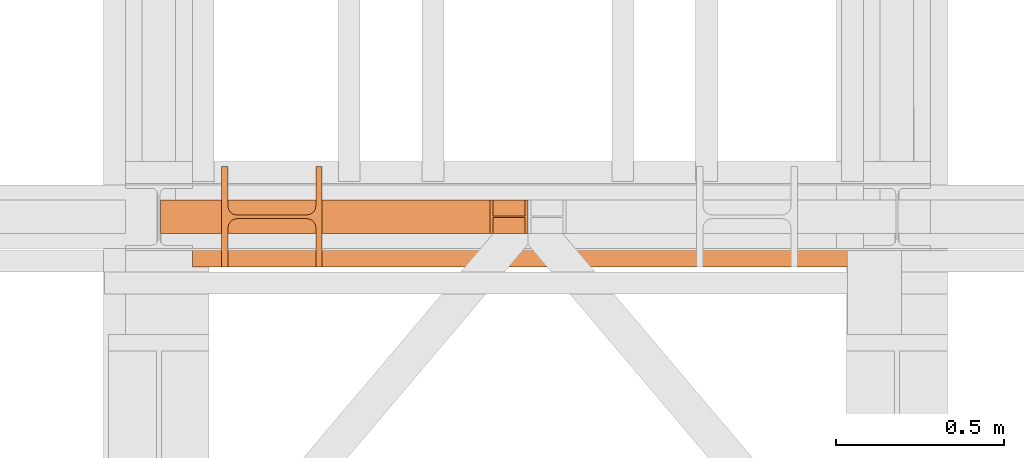
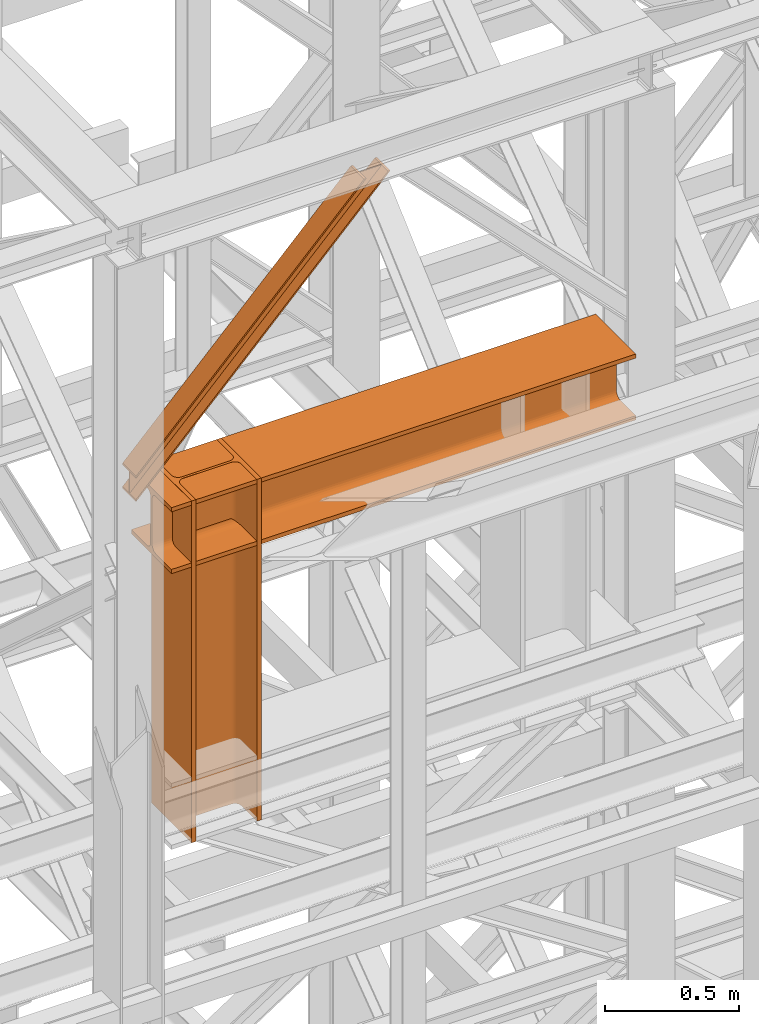
# One storey, part 146 of 208: 3 proxies.
"""IFC2X3 building model written with IfcOpenShell, lengths in millimetres."""

import ifcopenshell
import ifcopenshell.guid

model = None  # the IFC model being written
_history = None  # IfcOwnerHistory: only IFC2X3 demands one
_inside = {}  # id of a spatial element -> (the spatial element, [elements in it])
_under = {}  # id of a project, library or spatial element -> (it, [spatial elements below it])
_declared = {}  # id of a project -> (the project, [libraries it declares])
_typed = {}  # id of a type object -> (the type object, [elements of that type])
_made_of = {}  # id of a material, layer set ... -> (it, [elements and type objects made of it])


def new_model(schema):
    """Start an empty IFC model of exactly this schema.

    Asked for "IFC4X3", IfcOpenShell would pick the latest addendum, in which some entities
    have other attributes; the version numbers below select the first issue.
    IFC2X3 requires an IfcOwnerHistory on every rooted entity: one is made here for all.
    """
    global model, _history
    if schema == "IFC4X3":
        model = ifcopenshell.file(schema_version=(4, 3, 0, 0))
    else:
        model = ifcopenshell.file(schema=schema)
    _inside.clear()
    _under.clear()
    _declared.clear()
    _typed.clear()
    _made_of.clear()
    _history = None
    if model.schema == "IFC2X3":
        org = make("IfcOrganization", Name="unknown")
        user = make(
            "IfcPersonAndOrganization",
            ThePerson=make("IfcPerson", FamilyName="unknown"),
            TheOrganization=org,
        )
        app = make(
            "IfcApplication",
            ApplicationDeveloper=org,
            Version="unknown",
            ApplicationFullName="unknown",
            ApplicationIdentifier="unknown",
        )
        _history = make(
            "IfcOwnerHistory",
            OwningUser=user,
            OwningApplication=app,
            ChangeAction="ADDED",
            CreationDate=0,
        )
    return model


def make(cls, **values):
    """One entity of the class cls with the attributes given. An attribute that is None is left unset."""
    return model.create_entity(
        cls, **{name: value for name, value in values.items() if value is not None}
    )


def entity(cls, *values):
    """Any entity or typed value of the class cls, its attributes in the order of the schema. None: left unset."""
    e = model.create_entity(cls)
    for i, value in enumerate(values):
        if value is not None:
            e[i] = value
    return e


def rooted(cls, **values):
    """An entity with a GlobalId (a new one), such as an element, a storey or a relation."""
    return make(cls, GlobalId=ifcopenshell.guid.new(), OwnerHistory=_history, **values)


def si_unit(unit_type, name, prefix=None):
    """IfcSIUnit, for example si_unit("LENGTHUNIT", "METRE", prefix="MILLI")."""
    return make("IfcSIUnit", UnitType=unit_type, Prefix=prefix, Name=name)


def converted_unit(unit_type, name, factor, base, dimensions=None, offset=None):
    """IfcConversionBasedUnit, such as the inch: factor (a typed value) times the base unit."""
    return make(
        "IfcConversionBasedUnit"
        if offset is None
        else "IfcConversionBasedUnitWithOffset",
        ConversionOffset=offset,
        Dimensions=None
        if dimensions is None
        else entity("IfcDimensionalExponents", *dimensions),
        UnitType=unit_type,
        Name=name,
        ConversionFactor=make(
            "IfcMeasureWithUnit", ValueComponent=factor, UnitComponent=base
        ),
    )


def assignment(units):
    """IfcUnitAssignment: the units of a project."""
    return None if units is None else make("IfcUnitAssignment", Units=units)


def point(xyz):
    """IfcCartesianPoint."""
    return None if xyz is None else make("IfcCartesianPoint", Coordinates=xyz)


def direction(xyz):
    """IfcDirection."""
    return None if xyz is None else make("IfcDirection", DirectionRatios=xyz)


def frame(location, z_axis=None, x_axis=None):
    """IfcAxis2Placement3D, a coordinate frame: its origin and axes. An axis left out is left unset."""
    return make(
        "IfcAxis2Placement3D",
        Location=point(location),
        Axis=direction(z_axis),
        RefDirection=direction(x_axis),
    )


def origin():
    """The frame at (0, 0, 0) with its axes left unset."""
    return frame((0.0, 0.0, 0.0))


def origin_with_axes():
    """The frame at (0, 0, 0) with the z axis (0, 0, 1) and the x axis (1, 0, 0) written out."""
    return frame((0.0, 0.0, 0.0), z_axis=(0.0, 0.0, 1.0), x_axis=(1.0, 0.0, 0.0))


def place(relative_to, where):
    """IfcLocalPlacement: puts the frame where relative to a parent placement (None: the world)."""
    return make(
        "IfcLocalPlacement", PlacementRelTo=relative_to, RelativePlacement=where
    )


def context(
    kind, dimensions, precision=None, world=None, true_north=None, identifier=None
):
    """IfcGeometricRepresentationContext, for example the 3D "Model" context."""
    return make(
        "IfcGeometricRepresentationContext",
        ContextIdentifier=identifier,
        ContextType=kind,
        CoordinateSpaceDimension=dimensions,
        Precision=precision,
        WorldCoordinateSystem=world,
        TrueNorth=true_north,
    )


def subcontext(parent, identifier, kind, view, scale=None):
    """IfcGeometricRepresentationSubContext, for example "Body" below "Model"."""
    return make(
        "IfcGeometricRepresentationSubContext",
        ContextIdentifier=identifier,
        ContextType=kind,
        ParentContext=parent,
        TargetScale=scale,
        TargetView=view,
    )


def project(units=None, contexts=None):
    """IfcProject with its units and contexts."""
    return rooted(
        "IfcProject",
        Name="project",
        RepresentationContexts=contexts,
        UnitsInContext=assignment(units),
    )


def spatial(cls, under=None, at=None, **own):
    """A site, building, storey or space (cls), placed at a placement, below another one or the project."""
    s = rooted(cls, ObjectPlacement=at, **own)
    if under is not None:
        _under.setdefault(under.id(), (under, []))[1].append(s)
    return s


def faces_of(points, faces, orient=None, outer=None):
    """IfcFace entities. A face is a list of loops; a loop is a list of indices into points, from 0.

    orient and outer hold one flag for each loop. By default every Orientation is true, the
    first loop of a face is its IfcFaceOuterBound and the others are IfcFaceBound.
    """
    made = []
    for i, loops in enumerate(faces):
        bounds = []
        for j, loop in enumerate(loops):
            is_outer = j == 0 if outer is None else outer[i][j]
            bounds.append(
                make(
                    "IfcFaceOuterBound" if is_outer else "IfcFaceBound",
                    Bound=make("IfcPolyLoop", Polygon=[points[k] for k in loop]),
                    Orientation=True if orient is None else orient[i][j],
                )
            )
        made.append(make("IfcFace", Bounds=bounds))
    return made


def faceted_brep(points, faces, orient=None, outer=None, voids=None):
    """IfcFacetedBrep: a solid bounded by flat faces; with voids (closed shells), ...WithVoids."""
    shared = [point(p) for p in points]
    hull = make("IfcClosedShell", CfsFaces=faces_of(shared, faces, orient, outer))
    if voids is None:
        return make("IfcFacetedBrep", Outer=hull)
    return make(
        "IfcFacetedBrepWithVoids",
        Outer=hull,
        Voids=[
            make(cls, CfsFaces=faces_of(shared, fs, o, b)) for cls, fs, o, b in voids
        ],
    )


def shape(context_of_items, identifier, shape_type, items):
    """IfcShapeRepresentation: the items that make up one representation, for example the "Body"."""
    return make(
        "IfcShapeRepresentation",
        ContextOfItems=context_of_items,
        RepresentationIdentifier=identifier,
        RepresentationType=shape_type,
        Items=items,
    )


def made_of(thing, what):
    """Note that an element or type object is made of a material, layer set ...; save() writes the relation."""
    if what is not None:
        _made_of.setdefault(what.id(), (what, []))[1].append(thing)
    return thing


def element(
    cls,
    number,
    at=None,
    inside=None,
    cuts=None,
    type_object=None,
    material=None,
    context=None,
    identifier="Body",
    shape_type=None,
    held_by="IfcProductDefinitionShape",
    body=None,
    shapes=None,
    **own,
):
    """One element of the class cls, such as IfcWall. Its Tag is "e" and its number.

    at: its placement. inside: the storey or other place that contains it. cuts: it is an
    opening in that element (IfcRelVoidsElement). A single representation is given by context,
    identifier, shape_type and body (its items); several are given by shapes. held_by: the class
    of the entity that holds the representations. save() writes the other relations.
    """
    e = rooted(cls, Tag="e%d" % number, ObjectPlacement=at, **own)
    if body is not None:
        shapes = [shape(context, identifier, shape_type, body)]
    if shapes is not None:
        e.Representation = make(held_by, Representations=shapes)
    if inside is not None:
        _inside.setdefault(inside.id(), (inside, []))[1].append(e)
    if cuts is not None:
        rooted(
            "IfcRelVoidsElement", RelatingBuildingElement=cuts, RelatedOpeningElement=e
        )
    if type_object is not None:
        _typed.setdefault(type_object.id(), (type_object, []))[1].append(e)
    return made_of(e, material)


def aggregate(whole, parts):
    """IfcRelAggregates: a whole, such as a stair, and the parts it consists of."""
    return rooted("IfcRelAggregates", RelatingObject=whole, RelatedObjects=parts)


def save(model, path):
    """Write the relations noted so far, then the file.

    IfcRelAggregates (storeys below a building ...), IfcRelContainedInSpatialStructure (elements
    in a storey), IfcRelDefinesByType, IfcRelAssociatesMaterial and IfcRelDeclares: one each for
    every whole, place, type object, material and project.
    """
    for whole, parts in _under.values():
        aggregate(whole, parts)
    for where, things in _inside.values():
        rooted(
            "IfcRelContainedInSpatialStructure",
            RelatedElements=things,
            RelatingStructure=where,
        )
    for kind, things in _typed.values():
        rooted("IfcRelDefinesByType", RelatedObjects=things, RelatingType=kind)
    for what, things in _made_of.values():
        rooted("IfcRelAssociatesMaterial", RelatedObjects=things, RelatingMaterial=what)
    for by, libraries in _declared.values():
        rooted("IfcRelDeclares", RelatingContext=by, RelatedDefinitions=libraries)
    model.write(path)


model = new_model("IFC2X3")

# Units and contexts
model_context = context("Model", 3, precision=1e-05, world=origin())
plan_context = context("Plan", 3, precision=1e-05, world=origin())
body_context = subcontext(model_context, "Body", "Model", "MODEL_VIEW")
ifc_project = project(units=[si_unit("LENGTHUNIT", "METRE", prefix="MILLI"), converted_unit("PLANEANGLEUNIT", "DEGREE", entity("IfcPlaneAngleMeasure", 0.0174532925199433), si_unit("PLANEANGLEUNIT", "RADIAN"), dimensions=[0, 0, 0, 0, 0, 0, 0]), si_unit("AREAUNIT", "SQUARE_METRE"), si_unit("VOLUMEUNIT", "CUBIC_METRE")], contexts=[model_context, plan_context])

# Building, storey
building_placement = place(None, origin())
building = spatial("IfcBuilding", under=ifc_project, at=building_placement, CompositionType="COMPLEX")
storey_placement = place(building_placement, origin_with_axes())
storey = spatial("IfcBuildingStorey", under=building, at=storey_placement, Name="Geschoss", CompositionType="ELEMENT")

# Proxies
proxy_1_placement = place(storey_placement, frame((3393.254970018782, -16112.48734116498, 10824.99005869381), z_axis=(0.0, 0.0, 1.0), x_axis=(1.0, 0.0, 0.0)))
element("IfcBuildingElementProxy", 1, at=proxy_1_placement, inside=storey, context=body_context, shape_type="Brep", body=[
    faceted_brep([(0.01000000000021828, 300.0100000000002, 0.01000000000021828), (2000.009997019768, 300.0100000000002, 0.01000000000021828), (2000.009997019768, 300.0100000000002, 19.01000000000022), (0.01000000000021828, 300.0100000000002, 19.01000000000022), (0.01000000000021828, 300.0100000000002, 19.01000000000022), (2000.009997019768, 300.0100000000002, 19.01000000000022), (2000.009997019768, 182.5100000000002, 19.01000000000022), (0.01000000000021828, 182.5100000000002, 19.01000000000022), (0.01000000000021828, 182.5100000000002, 19.01000000000022), (2000.009997019768, 182.5100000000002, 19.01000000000022), (2000.009997019768, 175.5219092192219, 19.93008181249388), (0.01000000000021828, 175.5219092192219, 19.93008181249388), (0.01000000000021828, 175.5219092192219, 19.93008181249388), (2000.009997019768, 175.5219092192219, 19.93008181249388), (2000.009997019768, 169.0100393754565, 22.62738661818912), (0.01000000000021828, 169.0100393754565, 22.62738661818912), (0.01000000000021828, 169.0100393754565, 22.62738661818912), (2000.009997019768, 169.0100393754565, 22.62738661818912), (2000.009997019768, 163.4181169079584, 26.91811690796385), (0.01000000000021828, 163.4181169079584, 26.91811690796203), (0.01000000000021828, 163.4181169079584, 26.91811690796203), (2000.009997019768, 163.4181169079584, 26.91811690796385), (2000.009997019768, 159.1273866181855, 32.51003937545829), (0.01000000000021828, 159.1273866181855, 32.51003937545829), (0.01000000000021828, 159.1273866181855, 32.51003937545829), (2000.009997019768, 159.1273866181855, 32.51003937545829), (2000.009997019768, 156.4300818124921, 39.02190921922374), (0.01000000000021828, 156.4300818124921, 39.02190921922374), (0.01000000000021828, 156.4300818124921, 39.02190921922374), (2000.009997019768, 156.4300818124921, 39.02190921922374), (2000.009997019768, 155.5100000000002, 46.01000000000022), (0.01000000000021828, 155.5100000000002, 46.01000000000022), (0.01000000000021828, 155.5100000000002, 46.01000000000022), (2000.009997019768, 155.5100000000002, 46.01000000000022), (2000.009997019768, 155.5100000000002, 254.0100000000002), (0.01000000000021828, 155.5100000000002, 254.0100000000002), (0.01000000000021828, 155.5100000000002, 254.0100000000002), (2000.009997019768, 155.5100000000002, 254.0100000000002), (2000.009997019768, 156.8315660577409, 262.3534305458597), (0.01000000000021828, 156.8315660577409, 262.3534305458597), (0.01000000000021828, 156.8315660577409, 262.3534305458597), (2000.009997019768, 156.8315660577409, 262.3534305458597), (2000.009997019768, 160.6665745365954, 269.8801750658022), (0.01000000000021828, 160.6665745365954, 269.8801750658004), (0.01000000000021828, 160.6665745365954, 269.8801750658004), (2000.009997019768, 160.6665745365954, 269.8801750658022), (2000.009997019768, 166.6398249341964, 275.8534254634014), (0.01000000000021828, 166.6398249341964, 275.8534254634014), (0.01000000000021828, 166.6398249341964, 275.8534254634014), (2000.009997019768, 166.6398249341964, 275.8534254634014), (2000.009997019768, 174.1665694541352, 279.6884339422595), (0.01000000000021828, 174.1665694541352, 279.6884339422595), (0.01000000000021828, 174.1665694541352, 279.6884339422595), (2000.009997019768, 174.1665694541352, 279.6884339422595), (2000.009997019768, 182.5100000000002, 281.0100000000002), (0.01000000000021828, 182.5100000000002, 281.0100000000002), (0.01000000000021828, 182.5100000000002, 281.0100000000002), (2000.009997019768, 182.5100000000002, 281.0100000000002), (2000.009997019768, 300.0100000000002, 281.0100000000002), (0.01000000000021828, 300.0100000000002, 281.0100000000002), (0.01000000000021828, 300.0100000000002, 281.0100000000002), (2000.009997019768, 300.0100000000002, 281.0100000000002), (2000.009997019768, 300.0100000000002, 300.0100000000002), (0.01000000000021828, 300.0100000000002, 300.0100000000002), (0.01000000000021828, 300.0100000000002, 300.0100000000002), (2000.009997019768, 300.0100000000002, 300.0100000000002), (2000.009997019768, 0.01000000000021828, 300.0100000000002), (0.01000000000021828, 0.01000000000021828, 300.0100000000002), (0.01000000000021828, 0.01000000000021828, 300.0100000000002), (2000.009997019768, 0.01000000000021828, 300.0100000000002), (2000.009997019768, 0.01000000000021828, 281.0100000000002), (0.01000000000021828, 0.01000000000021828, 281.0100000000002), (0.01000000000021828, 0.01000000000021828, 281.0100000000002), (2000.009997019768, 0.01000000000021828, 281.0100000000002), (2000.009997019768, 117.5100000000002, 281.0100000000002), (0.01000000000021828, 117.5100000000002, 281.0100000000002), (0.01000000000021828, 117.5100000000002, 281.0100000000002), (2000.009997019768, 117.5100000000002, 281.0100000000002), (2000.009997019768, 125.8534305458579, 279.6884339422595), (0.01000000000021828, 125.8534305458579, 279.6884339422595), (0.01000000000021828, 125.8534305458579, 279.6884339422595), (2000.009997019768, 125.8534305458579, 279.6884339422595), (2000.009997019768, 133.3801750658004, 275.8534254634014), (0.01000000000021828, 133.3801750658004, 275.8534254634014), (0.01000000000021828, 133.3801750658004, 275.8534254634014), (2000.009997019768, 133.3801750658004, 275.8534254634014), (2000.009997019768, 139.3534254633978, 269.8801750658022), (0.01000000000021828, 139.3534254633978, 269.8801750658004), (0.01000000000021828, 139.3534254633978, 269.8801750658004), (2000.009997019768, 139.3534254633978, 269.8801750658022), (2000.009997019768, 143.1884339422595, 262.3534305458616), (0.01000000000021828, 143.1884339422595, 262.3534305458616), (0.01000000000021828, 143.1884339422595, 262.3534305458616), (2000.009997019768, 143.1884339422595, 262.3534305458616), (2000.009997019768, 144.5100000000002, 254.0100000000002), (0.01000000000021828, 144.5100000000002, 254.0100000000002), (0.01000000000021828, 144.5100000000002, 254.0100000000002), (2000.009997019768, 144.5100000000002, 254.0100000000002), (2000.009997019768, 144.5100000000002, 46.01000000000022), (0.01000000000021828, 144.5100000000002, 46.01000000000022), (0.01000000000021828, 144.5100000000002, 46.01000000000022), (2000.009997019768, 144.5100000000002, 46.01000000000022), (2000.009997019768, 143.1884339422595, 37.66656945413888), (0.01000000000021828, 143.1884339422595, 37.66656945413888), (0.01000000000021828, 143.1884339422595, 37.66656945413888), (2000.009997019768, 143.1884339422595, 37.66656945413888), (2000.009997019768, 139.3534254633978, 30.13982493419826), (0.01000000000021828, 139.3534254633978, 30.13982493419826), (0.01000000000021828, 139.3534254633978, 30.13982493419826), (2000.009997019768, 139.3534254633978, 30.13982493419826), (2000.009997019768, 133.3801750658004, 24.16657453659718), (0.01000000000021828, 133.3801750658004, 24.16657453659718), (0.01000000000021828, 133.3801750658004, 24.16657453659718), (2000.009997019768, 133.3801750658004, 24.16657453659718), (2000.009997019768, 125.8534305458579, 20.33156605774093), (0.01000000000021828, 125.8534305458579, 20.33156605774093), (0.01000000000021828, 125.8534305458579, 20.33156605774093), (2000.009997019768, 125.8534305458579, 20.33156605774093), (2000.009997019768, 117.5100000000002, 19.01000000000022), (0.01000000000021828, 117.5100000000002, 19.01000000000022), (0.01000000000021828, 117.5100000000002, 19.01000000000022), (2000.009997019768, 117.5100000000002, 19.01000000000022), (2000.009997019768, 0.01000000000021828, 19.01000000000022), (0.01000000000021828, 0.01000000000021828, 19.01000000000022), (0.01000000000021828, 0.01000000000021828, 19.01000000000022), (2000.009997019768, 0.01000000000021828, 19.01000000000022), (2000.009997019768, 0.01000000000021828, 0.01000000000021828), (0.01000000000021828, 0.01000000000021828, 0.01000000000021828), (0.01000000000021828, 0.01000000000021828, 0.01000000000021828), (2000.009997019768, 0.01000000000021828, 0.01000000000021828), (2000.009997019768, 300.0100000000002, 0.01000000000021828), (0.01000000000021828, 300.0100000000002, 0.01000000000021828), (0.01000000000021828, 300.0100000000002, 0.01000000000021828), (0.01000000000021828, 300.0100000000002, 19.01000000000022), (0.01000000000021828, 182.5100000000002, 19.01000000000022), (0.01000000000021828, 175.5219092192219, 19.93008181249388), (0.01000000000021828, 169.0100393754565, 22.62738661818912), (0.01000000000021828, 163.4181169079584, 26.91811690796203), (0.01000000000021828, 159.1273866181855, 32.51003937545829), (0.01000000000021828, 156.4300818124921, 39.02190921922374), (0.01000000000021828, 155.5100000000002, 46.01000000000022), (0.01000000000021828, 155.5100000000002, 254.0100000000002), (0.01000000000021828, 156.8315660577409, 262.3534305458597), (0.01000000000021828, 160.6665745365954, 269.8801750658004), (0.01000000000021828, 166.6398249341964, 275.8534254634014), (0.01000000000021828, 174.1665694541352, 279.6884339422595), (0.01000000000021828, 182.5100000000002, 281.0100000000002), (0.01000000000021828, 300.0100000000002, 281.0100000000002), (0.01000000000021828, 300.0100000000002, 300.0100000000002), (0.01000000000021828, 0.01000000000021828, 300.0100000000002), (0.01000000000021828, 0.01000000000021828, 281.0100000000002), (0.01000000000021828, 117.5100000000002, 281.0100000000002), (0.01000000000021828, 125.8534305458579, 279.6884339422595), (0.01000000000021828, 133.3801750658004, 275.8534254634014), (0.01000000000021828, 139.3534254633978, 269.8801750658004), (0.01000000000021828, 143.1884339422595, 262.3534305458616), (0.01000000000021828, 144.5100000000002, 254.0100000000002), (0.01000000000021828, 144.5100000000002, 46.01000000000022), (0.01000000000021828, 143.1884339422595, 37.66656945413888), (0.01000000000021828, 139.3534254633978, 30.13982493419826), (0.01000000000021828, 133.3801750658004, 24.16657453659718), (0.01000000000021828, 125.8534305458579, 20.33156605774093), (0.01000000000021828, 117.5100000000002, 19.01000000000022), (0.01000000000021828, 0.01000000000021828, 19.01000000000022), (0.01000000000021828, 0.01000000000021828, 0.01000000000021828), (2000.009997019768, 300.0100000000002, 0.01000000000021828), (2000.009997019768, 0.01000000000021828, 0.01000000000021828), (2000.009997019768, 0.01000000000021828, 19.01000000000022), (2000.009997019768, 117.5100000000002, 19.01000000000022), (2000.009997019768, 125.8534305458579, 20.33156605774093), (2000.009997019768, 133.3801750658004, 24.16657453659718), (2000.009997019768, 139.3534254633978, 30.13982493419826), (2000.009997019768, 143.1884339422595, 37.66656945413888), (2000.009997019768, 144.5100000000002, 46.01000000000022), (2000.009997019768, 144.5100000000002, 254.0100000000002), (2000.009997019768, 143.1884339422595, 262.3534305458616), (2000.009997019768, 139.3534254633978, 269.8801750658022), (2000.009997019768, 133.3801750658004, 275.8534254634014), (2000.009997019768, 125.8534305458579, 279.6884339422595), (2000.009997019768, 117.5100000000002, 281.0100000000002), (2000.009997019768, 0.01000000000021828, 281.0100000000002), (2000.009997019768, 0.01000000000021828, 300.0100000000002), (2000.009997019768, 300.0100000000002, 300.0100000000002), (2000.009997019768, 300.0100000000002, 281.0100000000002), (2000.009997019768, 182.5100000000002, 281.0100000000002), (2000.009997019768, 174.1665694541352, 279.6884339422595), (2000.009997019768, 166.6398249341964, 275.8534254634014), (2000.009997019768, 160.6665745365954, 269.8801750658022), (2000.009997019768, 156.8315660577409, 262.3534305458597), (2000.009997019768, 155.5100000000002, 254.0100000000002), (2000.009997019768, 155.5100000000002, 46.01000000000022), (2000.009997019768, 156.4300818124921, 39.02190921922374), (2000.009997019768, 159.1273866181855, 32.51003937545829), (2000.009997019768, 163.4181169079584, 26.91811690796385), (2000.009997019768, 169.0100393754565, 22.62738661818912), (2000.009997019768, 175.5219092192219, 19.93008181249388), (2000.009997019768, 182.5100000000002, 19.01000000000022), (2000.009997019768, 300.0100000000002, 19.01000000000022)], [[[0, 1, 2, 3]], [[4, 5, 6, 7]], [[8, 9, 10, 11]], [[12, 13, 14, 15]], [[16, 17, 18, 19]], [[20, 21, 22, 23]], [[24, 25, 26, 27]], [[28, 29, 30, 31]], [[32, 33, 34, 35]], [[36, 37, 38, 39]], [[40, 41, 42, 43]], [[44, 45, 46, 47]], [[48, 49, 50, 51]], [[52, 53, 54, 55]], [[56, 57, 58, 59]], [[60, 61, 62, 63]], [[64, 65, 66, 67]], [[68, 69, 70, 71]], [[72, 73, 74, 75]], [[76, 77, 78, 79]], [[80, 81, 82, 83]], [[84, 85, 86, 87]], [[88, 89, 90, 91]], [[92, 93, 94, 95]], [[96, 97, 98, 99]], [[100, 101, 102, 103]], [[104, 105, 106, 107]], [[108, 109, 110, 111]], [[112, 113, 114, 115]], [[116, 117, 118, 119]], [[120, 121, 122, 123]], [[124, 125, 126, 127]], [[128, 129, 130, 131]], [[132, 133, 134, 135, 136, 137, 138, 139, 140, 141, 142, 143, 144, 145, 146, 147, 148, 149, 150, 151, 152, 153, 154, 155, 156, 157, 158, 159, 160, 161, 162, 163, 164]], [[165, 166, 167, 168, 169, 170, 171, 172, 173, 174, 175, 176, 177, 178, 179, 180, 181, 182, 183, 184, 185, 186, 187, 188, 189, 190, 191, 192, 193, 194, 195, 196, 197]]], orient=[[False], [False], [False], [False], [False], [False], [False], [False], [False], [False], [False], [False], [False], [False], [False], [False], [False], [False], [False], [False], [False], [False], [False], [False], [False], [False], [False], [False], [False], [False], [False], [False], [False], [False], [False]]),
])
proxy_2_placement = place(storey_placement, frame((3480.254970018783, -16112.48734116498, 9568.99005869381), z_axis=(0.0, 0.0, 1.0), x_axis=(1.0, 0.0, 0.0)))
element("IfcBuildingElementProxy", 2, at=proxy_2_placement, inside=storey, context=body_context, shape_type="Brep", body=[
    faceted_brep([(0.01000000000021828, 300.0100000000002, 1556.01), (0.01000000000021828, 300.0100000000002, 0.01000000000021828), (19.01000000000022, 300.0100000000002, 0.01000000000021828), (19.01000000000022, 300.0100000000002, 1556.01), (19.01000000000022, 300.0100000000002, 1556.01), (19.01000000000022, 300.0100000000002, 0.01000000000021828), (19.01000000000022, 182.5100000000002, 0.01000000000021828), (19.01000000000022, 182.5100000000002, 1556.01), (19.01000000000022, 182.5100000000002, 1556.01), (19.01000000000022, 182.5100000000002, 0.01000000000021828), (19.93008181249388, 175.5219092192219, 0.01000000000021828), (19.93008181249388, 175.5219092192219, 1556.01), (19.93008181249388, 175.5219092192219, 1556.01), (19.93008181249388, 175.5219092192219, 0.01000000000021828), (22.62738661818912, 169.0100393754565, 0.01000000000021828), (22.62738661818912, 169.0100393754565, 1556.01), (22.62738661818912, 169.0100393754565, 1556.01), (22.62738661818912, 169.0100393754565, 0.01000000000021828), (26.91811690796385, 163.4181169079584, 0.01000000000021828), (26.91811690796203, 163.4181169079584, 1556.01), (26.91811690796203, 163.4181169079584, 1556.01), (26.91811690796385, 163.4181169079584, 0.01000000000021828), (32.51003937545829, 159.1273866181855, 0.01000000000021828), (32.51003937545829, 159.1273866181855, 1556.01), (32.51003937545829, 159.1273866181855, 1556.01), (32.51003937545829, 159.1273866181855, 0.01000000000021828), (39.02190921922374, 156.4300818124921, 0.01000000000021828), (39.02190921922374, 156.4300818124921, 1556.01), (39.02190921922374, 156.4300818124921, 1556.01), (39.02190921922374, 156.4300818124921, 0.01000000000021828), (46.01000000000022, 155.5100000000002, 0.01000000000021828), (46.01000000000022, 155.5100000000002, 1556.01), (46.01000000000022, 155.5100000000002, 1556.01), (46.01000000000022, 155.5100000000002, 0.01000000000021828), (254.0100000000002, 155.5100000000002, 0.01000000000021828), (254.0100000000002, 155.5100000000002, 1556.01), (254.0100000000002, 155.5100000000002, 1556.01), (254.0100000000002, 155.5100000000002, 0.01000000000021828), (262.3534305458597, 156.8315660577409, 0.01000000000021828), (262.3534305458597, 156.8315660577409, 1556.01), (262.3534305458597, 156.8315660577409, 1556.01), (262.3534305458597, 156.8315660577409, 0.01000000000021828), (269.8801750658022, 160.6665745365954, 0.01000000000021828), (269.8801750658004, 160.6665745365954, 1556.01), (269.8801750658004, 160.6665745365954, 1556.01), (269.8801750658022, 160.6665745365954, 0.01000000000021828), (275.8534254634014, 166.6398249341964, 0.01000000000021828), (275.8534254634014, 166.6398249341964, 1556.01), (275.8534254634014, 166.6398249341964, 1556.01), (275.8534254634014, 166.6398249341964, 0.01000000000021828), (279.6884339422595, 174.1665694541352, 0.01000000000021828), (279.6884339422595, 174.1665694541352, 1556.01), (279.6884339422595, 174.1665694541352, 1556.01), (279.6884339422595, 174.1665694541352, 0.01000000000021828), (281.0100000000002, 182.5100000000002, 0.01000000000021828), (281.0100000000002, 182.5100000000002, 1556.01), (281.0100000000002, 182.5100000000002, 1556.01), (281.0100000000002, 182.5100000000002, 0.01000000000021828), (281.0100000000002, 300.0100000000002, 0.01000000000021828), (281.0100000000002, 300.0100000000002, 1556.01), (281.0100000000002, 300.0100000000002, 1556.01), (281.0100000000002, 300.0100000000002, 0.01000000000021828), (300.0100000000002, 300.0100000000002, 0.01000000000021828), (300.0100000000002, 300.0100000000002, 1556.01), (300.0100000000002, 300.0100000000002, 1556.01), (300.0100000000002, 300.0100000000002, 0.01000000000021828), (300.0100000000002, 0.01000000000021828, 0.01000000000021828), (300.0100000000002, 0.01000000000021828, 1556.01), (300.0100000000002, 0.01000000000021828, 1556.01), (300.0100000000002, 0.01000000000021828, 0.01000000000021828), (281.0100000000002, 0.01000000000021828, 0.01000000000021828), (281.0100000000002, 0.01000000000021828, 1556.01), (281.0100000000002, 0.01000000000021828, 1556.01), (281.0100000000002, 0.01000000000021828, 0.01000000000021828), (281.0100000000002, 117.5100000000002, 0.01000000000021828), (281.0100000000002, 117.5100000000002, 1556.01), (281.0100000000002, 117.5100000000002, 1556.01), (281.0100000000002, 117.5100000000002, 0.01000000000021828), (279.6884339422595, 125.8534305458579, 0.01000000000021828), (279.6884339422595, 125.8534305458579, 1556.01), (279.6884339422595, 125.8534305458579, 1556.01), (279.6884339422595, 125.8534305458579, 0.01000000000021828), (275.8534254634014, 133.3801750658004, 0.01000000000021828), (275.8534254634014, 133.3801750658004, 1556.01), (275.8534254634014, 133.3801750658004, 1556.01), (275.8534254634014, 133.3801750658004, 0.01000000000021828), (269.8801750658022, 139.3534254633978, 0.01000000000021828), (269.8801750658004, 139.3534254633978, 1556.01), (269.8801750658004, 139.3534254633978, 1556.01), (269.8801750658022, 139.3534254633978, 0.01000000000021828), (262.3534305458616, 143.1884339422595, 0.01000000000021828), (262.3534305458616, 143.1884339422595, 1556.01), (262.3534305458616, 143.1884339422595, 1556.01), (262.3534305458616, 143.1884339422595, 0.01000000000021828), (254.0100000000002, 144.5100000000002, 0.01000000000021828), (254.0100000000002, 144.5100000000002, 1556.01), (254.0100000000002, 144.5100000000002, 1556.01), (254.0100000000002, 144.5100000000002, 0.01000000000021828), (46.01000000000022, 144.5100000000002, 0.01000000000021828), (46.01000000000022, 144.5100000000002, 1556.01), (46.01000000000022, 144.5100000000002, 1556.01), (46.01000000000022, 144.5100000000002, 0.01000000000021828), (37.66656945413888, 143.1884339422595, 0.01000000000021828), (37.66656945413888, 143.1884339422595, 1556.01), (37.66656945413888, 143.1884339422595, 1556.01), (37.66656945413888, 143.1884339422595, 0.01000000000021828), (30.13982493419826, 139.3534254633978, 0.01000000000021828), (30.13982493419826, 139.3534254633978, 1556.01), (30.13982493419826, 139.3534254633978, 1556.01), (30.13982493419826, 139.3534254633978, 0.01000000000021828), (24.16657453659718, 133.3801750658004, 0.01000000000021828), (24.16657453659718, 133.3801750658004, 1556.01), (24.16657453659718, 133.3801750658004, 1556.01), (24.16657453659718, 133.3801750658004, 0.01000000000021828), (20.33156605774093, 125.8534305458579, 0.01000000000021828), (20.33156605774093, 125.8534305458579, 1556.01), (20.33156605774093, 125.8534305458579, 1556.01), (20.33156605774093, 125.8534305458579, 0.01000000000021828), (19.01000000000022, 117.5100000000002, 0.01000000000021828), (19.01000000000022, 117.5100000000002, 1556.01), (19.01000000000022, 117.5100000000002, 1556.01), (19.01000000000022, 117.5100000000002, 0.01000000000021828), (19.01000000000022, 0.01000000000021828, 0.01000000000021828), (19.01000000000022, 0.01000000000021828, 1556.01), (19.01000000000022, 0.01000000000021828, 1556.01), (19.01000000000022, 0.01000000000021828, 0.01000000000021828), (0.01000000000021828, 0.01000000000021828, 0.01000000000021828), (0.01000000000021828, 0.01000000000021828, 1556.01), (0.01000000000021828, 0.01000000000021828, 1556.01), (0.01000000000021828, 0.01000000000021828, 0.01000000000021828), (0.01000000000021828, 300.0100000000002, 0.01000000000021828), (0.01000000000021828, 300.0100000000002, 1556.01), (0.01000000000021828, 300.0100000000002, 1556.01), (19.01000000000022, 300.0100000000002, 1556.01), (19.01000000000022, 182.5100000000002, 1556.01), (19.93008181249388, 175.5219092192219, 1556.01), (22.62738661818912, 169.0100393754565, 1556.01), (26.91811690796203, 163.4181169079584, 1556.01), (32.51003937545829, 159.1273866181855, 1556.01), (39.02190921922374, 156.4300818124921, 1556.01), (46.01000000000022, 155.5100000000002, 1556.01), (254.0100000000002, 155.5100000000002, 1556.01), (262.3534305458597, 156.8315660577409, 1556.01), (269.8801750658004, 160.6665745365954, 1556.01), (275.8534254634014, 166.6398249341964, 1556.01), (279.6884339422595, 174.1665694541352, 1556.01), (281.0100000000002, 182.5100000000002, 1556.01), (281.0100000000002, 300.0100000000002, 1556.01), (300.0100000000002, 300.0100000000002, 1556.01), (300.0100000000002, 0.01000000000021828, 1556.01), (281.0100000000002, 0.01000000000021828, 1556.01), (281.0100000000002, 117.5100000000002, 1556.01), (279.6884339422595, 125.8534305458579, 1556.01), (275.8534254634014, 133.3801750658004, 1556.01), (269.8801750658004, 139.3534254633978, 1556.01), (262.3534305458616, 143.1884339422595, 1556.01), (254.0100000000002, 144.5100000000002, 1556.01), (46.01000000000022, 144.5100000000002, 1556.01), (37.66656945413888, 143.1884339422595, 1556.01), (30.13982493419826, 139.3534254633978, 1556.01), (24.16657453659718, 133.3801750658004, 1556.01), (20.33156605774093, 125.8534305458579, 1556.01), (19.01000000000022, 117.5100000000002, 1556.01), (19.01000000000022, 0.01000000000021828, 1556.01), (0.01000000000021828, 0.01000000000021828, 1556.01), (0.01000000000021828, 300.0100000000002, 0.01000000000021828), (0.01000000000021828, 0.01000000000021828, 0.01000000000021828), (19.01000000000022, 0.01000000000021828, 0.01000000000021828), (19.01000000000022, 117.5100000000002, 0.01000000000021828), (20.33156605774093, 125.8534305458579, 0.01000000000021828), (24.16657453659718, 133.3801750658004, 0.01000000000021828), (30.13982493419826, 139.3534254633978, 0.01000000000021828), (37.66656945413888, 143.1884339422595, 0.01000000000021828), (46.01000000000022, 144.5100000000002, 0.01000000000021828), (254.0100000000002, 144.5100000000002, 0.01000000000021828), (262.3534305458616, 143.1884339422595, 0.01000000000021828), (269.8801750658022, 139.3534254633978, 0.01000000000021828), (275.8534254634014, 133.3801750658004, 0.01000000000021828), (279.6884339422595, 125.8534305458579, 0.01000000000021828), (281.0100000000002, 117.5100000000002, 0.01000000000021828), (281.0100000000002, 0.01000000000021828, 0.01000000000021828), (300.0100000000002, 0.01000000000021828, 0.01000000000021828), (300.0100000000002, 300.0100000000002, 0.01000000000021828), (281.0100000000002, 300.0100000000002, 0.01000000000021828), (281.0100000000002, 182.5100000000002, 0.01000000000021828), (279.6884339422595, 174.1665694541352, 0.01000000000021828), (275.8534254634014, 166.6398249341964, 0.01000000000021828), (269.8801750658022, 160.6665745365954, 0.01000000000021828), (262.3534305458597, 156.8315660577409, 0.01000000000021828), (254.0100000000002, 155.5100000000002, 0.01000000000021828), (46.01000000000022, 155.5100000000002, 0.01000000000021828), (39.02190921922374, 156.4300818124921, 0.01000000000021828), (32.51003937545829, 159.1273866181855, 0.01000000000021828), (26.91811690796385, 163.4181169079584, 0.01000000000021828), (22.62738661818912, 169.0100393754565, 0.01000000000021828), (19.93008181249388, 175.5219092192219, 0.01000000000021828), (19.01000000000022, 182.5100000000002, 0.01000000000021828), (19.01000000000022, 300.0100000000002, 0.01000000000021828)], [[[0, 1, 2, 3]], [[4, 5, 6, 7]], [[8, 9, 10, 11]], [[12, 13, 14, 15]], [[16, 17, 18, 19]], [[20, 21, 22, 23]], [[24, 25, 26, 27]], [[28, 29, 30, 31]], [[32, 33, 34, 35]], [[36, 37, 38, 39]], [[40, 41, 42, 43]], [[44, 45, 46, 47]], [[48, 49, 50, 51]], [[52, 53, 54, 55]], [[56, 57, 58, 59]], [[60, 61, 62, 63]], [[64, 65, 66, 67]], [[68, 69, 70, 71]], [[72, 73, 74, 75]], [[76, 77, 78, 79]], [[80, 81, 82, 83]], [[84, 85, 86, 87]], [[88, 89, 90, 91]], [[92, 93, 94, 95]], [[96, 97, 98, 99]], [[100, 101, 102, 103]], [[104, 105, 106, 107]], [[108, 109, 110, 111]], [[112, 113, 114, 115]], [[116, 117, 118, 119]], [[120, 121, 122, 123]], [[124, 125, 126, 127]], [[128, 129, 130, 131]], [[132, 133, 134, 135, 136, 137, 138, 139, 140, 141, 142, 143, 144, 145, 146, 147, 148, 149, 150, 151, 152, 153, 154, 155, 156, 157, 158, 159, 160, 161, 162, 163, 164]], [[165, 166, 167, 168, 169, 170, 171, 172, 173, 174, 175, 176, 177, 178, 179, 180, 181, 182, 183, 184, 185, 186, 187, 188, 189, 190, 191, 192, 193, 194, 195, 196, 197]]], orient=[[False], [False], [False], [False], [False], [False], [False], [False], [False], [False], [False], [False], [False], [False], [False], [False], [False], [False], [False], [False], [False], [False], [False], [False], [False], [False], [False], [False], [False], [False], [False], [False], [False], [False], [False]]),
])
proxy_3_placement = place(storey_placement, frame((3298.369516902633, -16012.57439031789, 11124.99005869381), z_axis=(0.0, 0.0, 1.0), x_axis=(1.0, 0.0, 0.0)))
element("IfcBuildingElementProxy", 3, at=proxy_3_placement, inside=storey, context=body_context, shape_type="Brep", body=[
    faceted_brep([(1094.895451626033, 0.01000000000021828, 1125.010000000002), (0.01000000000021828, 0.01000000000203727, 0.01000000000203727), (0.01000000000021828, 0.01000000000203727, 9.69256505868907), (1085.472074188542, 0.01000000000021828, 1125.010000000004), (1094.895451626033, 100.0100000000002, 1125.010000000002), (0.01000000000021828, 100.010000000002, 0.01000000000021828), (0.01000000000021828, 0.01000000000203727, 0.01000000000203727), (1094.895451626033, 0.01000000000021828, 1125.010000000002), (1085.472074188542, 100.0100000000002, 1125.010000000004), (0.01000000000021828, 100.010000000002, 9.69256505868907), (0.01000000000021828, 100.010000000002, 0.01000000000021828), (1094.895451626033, 100.0100000000002, 1125.010000000002), (1085.472074188542, 52.51000000000022, 1125.010000000004), (0.01000000000021828, 52.51000000000204, 9.69256505868907), (0.01000000000021828, 100.010000000002, 9.69256505868907), (1085.472074188542, 100.0100000000002, 1125.010000000004), (991.2382998136163, 52.51000000000022, 1125.010000000002), (0.01000000000021828, 52.51000000000204, 106.5182156455558), (0.01000000000021828, 52.51000000000204, 9.69256505868907), (1085.472074188542, 52.51000000000022, 1125.010000000004), (991.23829981362, 100.0100000000002, 1125.010000000002), (0.01000000000203727, 100.010000000002, 106.5182156455558), (0.01000000000021828, 52.51000000000204, 106.5182156455558), (991.2382998136163, 52.51000000000022, 1125.010000000002), (981.8149223761275, 100.0100000000002, 1125.010000000002), (0.01000000000021828, 100.010000000002, 116.2007807042428), (0.01000000000203727, 100.010000000002, 106.5182156455558), (991.23829981362, 100.0100000000002, 1125.010000000002), (981.8149223761238, 0.01000000000021828, 1125.010000000002), (0.01000000000021828, 0.01000000000203727, 116.2007807042428), (0.01000000000021828, 100.010000000002, 116.2007807042428), (981.8149223761275, 100.0100000000002, 1125.010000000002), (991.23829981362, 0.01000000000021828, 1125.010000000002), (0.01000000000021828, 0.01000000000203727, 106.5182156455558), (0.01000000000021828, 0.01000000000203727, 116.2007807042428), (981.8149223761238, 0.01000000000021828, 1125.010000000002), (991.2382998136218, 47.51000000000022, 1125.01), (0.01000000000021828, 47.51000000000204, 106.5182156455558), (0.01000000000021828, 0.01000000000203727, 106.5182156455558), (991.23829981362, 0.01000000000021828, 1125.010000000002), (1085.472074188542, 47.51000000000022, 1125.010000000004), (0.01000000000021828, 47.51000000000204, 9.69256505868907), (0.01000000000021828, 47.51000000000204, 106.5182156455558), (991.2382998136218, 47.51000000000022, 1125.01), (1085.472074188542, 0.01000000000021828, 1125.010000000004), (0.01000000000021828, 0.01000000000203727, 9.69256505868907), (0.01000000000021828, 47.51000000000204, 9.69256505868907), (1085.472074188542, 47.51000000000022, 1125.010000000004), (0.01000000000021828, 0.01000000000203727, 0.01000000000203727), (0.01000000000021828, 100.010000000002, 0.01000000000021828), (0.01000000000021828, 100.010000000002, 9.69256505868907), (0.01000000000021828, 52.51000000000204, 9.69256505868907), (0.01000000000021828, 52.51000000000204, 106.5182156455558), (0.01000000000203727, 100.010000000002, 106.5182156455558), (0.01000000000021828, 100.010000000002, 116.2007807042428), (0.01000000000021828, 0.01000000000203727, 116.2007807042428), (0.01000000000021828, 0.01000000000203727, 106.5182156455558), (0.01000000000021828, 47.51000000000204, 106.5182156455558), (0.01000000000021828, 47.51000000000204, 9.69256505868907), (0.01000000000021828, 0.01000000000203727, 9.69256505868907), (1085.472074188542, 0.01000000000021828, 1125.010000000004), (1085.472074188542, 47.51000000000022, 1125.010000000004), (991.2382998136218, 47.51000000000022, 1125.01), (991.23829981362, 0.01000000000021828, 1125.010000000002), (981.8149223761238, 0.01000000000021828, 1125.010000000002), (981.8149223761275, 100.0100000000002, 1125.010000000002), (991.23829981362, 100.0100000000002, 1125.010000000002), (991.2382998136163, 52.51000000000022, 1125.010000000002), (1085.472074188542, 52.51000000000022, 1125.010000000004), (1085.472074188542, 100.0100000000002, 1125.010000000004), (1094.895451626033, 100.0100000000002, 1125.010000000002), (1094.895451626033, 0.01000000000021828, 1125.010000000002)], [[[0, 1, 2, 3]], [[4, 5, 6, 7]], [[8, 9, 10, 11]], [[12, 13, 14, 15]], [[16, 17, 18, 19]], [[20, 21, 22, 23]], [[24, 25, 26, 27]], [[28, 29, 30, 31]], [[32, 33, 34, 35]], [[36, 37, 38, 39]], [[40, 41, 42, 43]], [[44, 45, 46, 47]], [[48, 49, 50, 51, 52, 53, 54, 55, 56, 57, 58, 59]], [[60, 61, 62, 63, 64, 65, 66, 67, 68, 69, 70, 71]]], orient=[[False], [False], [False], [False], [False], [False], [False], [False], [False], [False], [False], [False], [False], [False]]),
])

save(model, "model.ifc")
